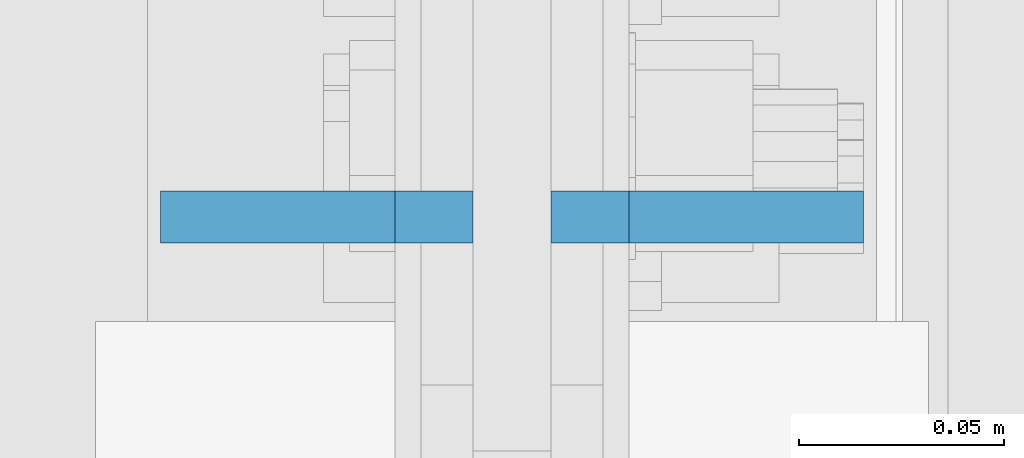
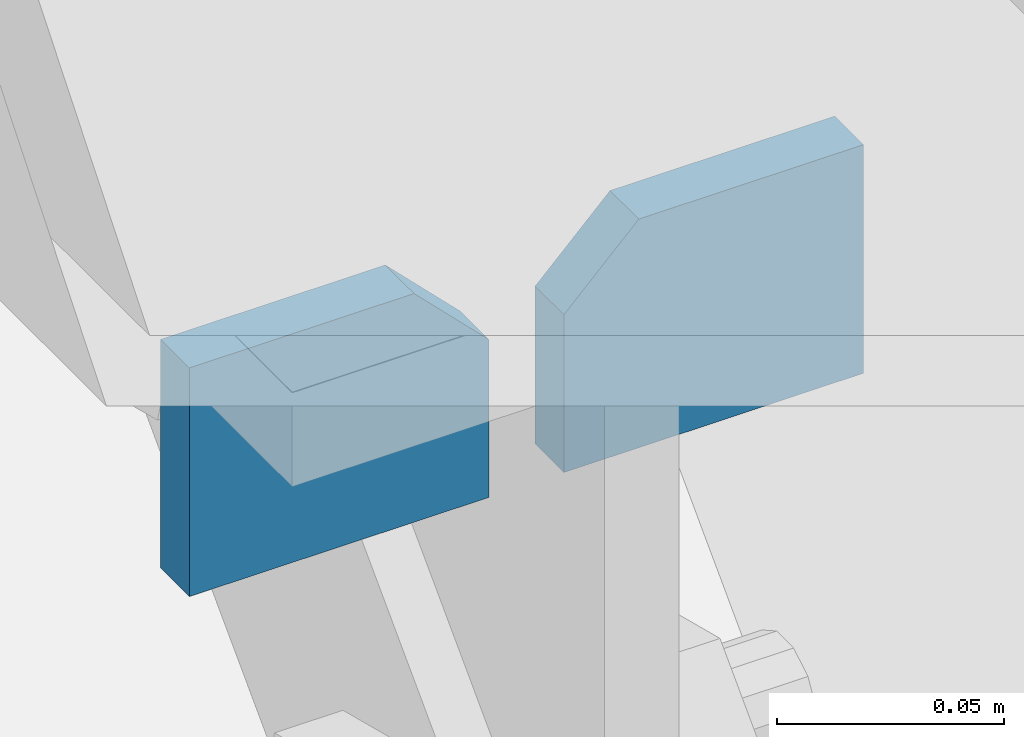
# One storey, part 1119 of 1179: 2 plates, 1 element without a shape of its own.
"""IFC2X3 building model written with IfcOpenShell, lengths in millimetres."""

from ifc_helpers import new_model, si_unit, frame, origin_with_axes, place, context, subcontext, project, spatial, faceted_brep, material, type_object, element, aggregate, save


model = new_model("IFC2X3")

# Units and contexts
model_context = context("Model", 3, precision=1e-05, world=origin_with_axes())
body_context = subcontext(model_context, "Body", "Model", "MODEL_VIEW")
ifc_project = project(units=[si_unit("LENGTHUNIT", "METRE", prefix="MILLI"), si_unit("AREAUNIT", "SQUARE_METRE"), si_unit("VOLUMEUNIT", "CUBIC_METRE"), si_unit("MASSUNIT", "GRAM", prefix="KILO"), si_unit("TIMEUNIT", "SECOND"), si_unit("PLANEANGLEUNIT", "RADIAN"), si_unit("SOLIDANGLEUNIT", "STERADIAN"), si_unit("THERMODYNAMICTEMPERATUREUNIT", "DEGREE_CELSIUS"), si_unit("LUMINOUSINTENSITYUNIT", "LUMEN")], contexts=[model_context])

# Site, building, storey
site_placement = place(None, origin_with_axes())
site = spatial("IfcSite", under=ifc_project, at=site_placement, CompositionType="ELEMENT")
building_placement = place(site_placement, origin_with_axes())
building = spatial("IfcBuilding", under=site, at=building_placement, Name="Undefined", CompositionType="ELEMENT")
storey_placement = place(building_placement, origin_with_axes())
storey = spatial("IfcBuildingStorey", under=building, at=storey_placement, Name="Undefined", CompositionType="ELEMENT", Elevation=0.0)

# Assembly, plates
assembly_placement = place(storey_placement, origin_with_axes())
assembly = element("IfcElementAssembly", 1, at=assembly_placement, inside=storey, Name="BEAM", AssemblyPlace="NOTDEFINED", PredefinedType="RIGID_FRAME")
ifc_material = material(Name="STEEL/A572-GR.50")
plate_type = type_object("IfcPlateType", PredefinedType="NOTDEFINED")
plate_1_placement = place(assembly_placement, frame((422.275000000003, 14935.2, 7683.5), z_axis=(-1.0, 0.0, 0.0), x_axis=(0.0, 0.0, -1.0)))
plate_1 = element("IfcPlate", 2, at=plate_1_placement, type_object=plate_type, material=ifc_material, Name="PLATE", context=body_context, shape_type="Brep", body=[
    faceted_brep([(0.0, 6.35000000000036, 19.0499999999993), (19.0500000000002, 6.35000000000036, 0.0), (19.0500000000002, -6.35000000000036, 0.0), (0.0, -6.35000000000036, 19.0499999999993), (0.0, -6.35000000000036, 76.2000000000044), (0.0, 6.35000000000036, 76.2000000000044), (61.493348936805, -6.35000000000036, 76.2000000000044), (61.493348936805, 6.35000000000036, 76.2000000000044), (61.493348936805, -6.35000000000036, 0.0), (61.493348936805, 6.35000000000036, 0.0)], [[[0, 1, 2, 3]], [[4, 5, 0, 3]], [[4, 6, 7, 5]], [[6, 8, 9, 7]], [[9, 8, 2, 1]], [[5, 7, 9, 1, 0]], [[8, 6, 4, 3, 2]]]),
])
plate_2_placement = place(assembly_placement, frame((441.325000000003, 14935.2, 7683.5), z_axis=(1.0, 0.0, 0.0), x_axis=(0.0, 0.0, -1.0)))
plate_2 = element("IfcPlate", 3, at=plate_2_placement, type_object=plate_type, material=ifc_material, Name="PLATE", context=body_context, shape_type="Brep", body=[
    faceted_brep([(0.0, 6.35000000000036, 19.0499999999993), (19.0500000000002, 6.35000000000036, 0.0), (19.0500000000002, -6.35000000000036, 0.0), (0.0, -6.35000000000036, 19.0499999999993), (0.0, -6.35000000000036, 76.2000000000044), (0.0, 6.35000000000036, 76.2000000000044), (61.493348936805, -6.35000000000036, 76.2000000000044), (61.493348936805, 6.35000000000036, 76.2000000000044), (61.493348936805, -6.35000000000036, 0.0), (61.493348936805, 6.35000000000036, 0.0)], [[[0, 1, 2, 3]], [[4, 5, 0, 3]], [[4, 6, 7, 5]], [[6, 8, 9, 7]], [[9, 8, 2, 1]], [[5, 7, 9, 1, 0]], [[8, 6, 4, 3, 2]]]),
])
aggregate(assembly, [plate_1, plate_2])

save(model, "model.ifc")
